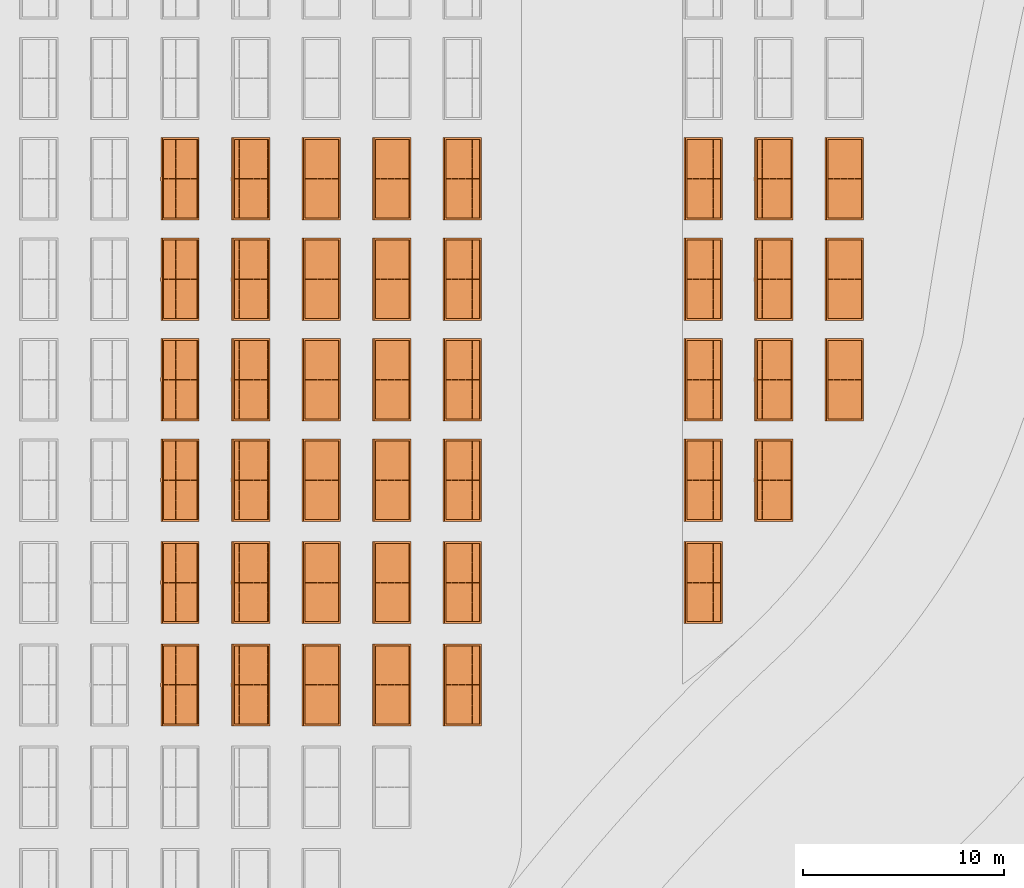
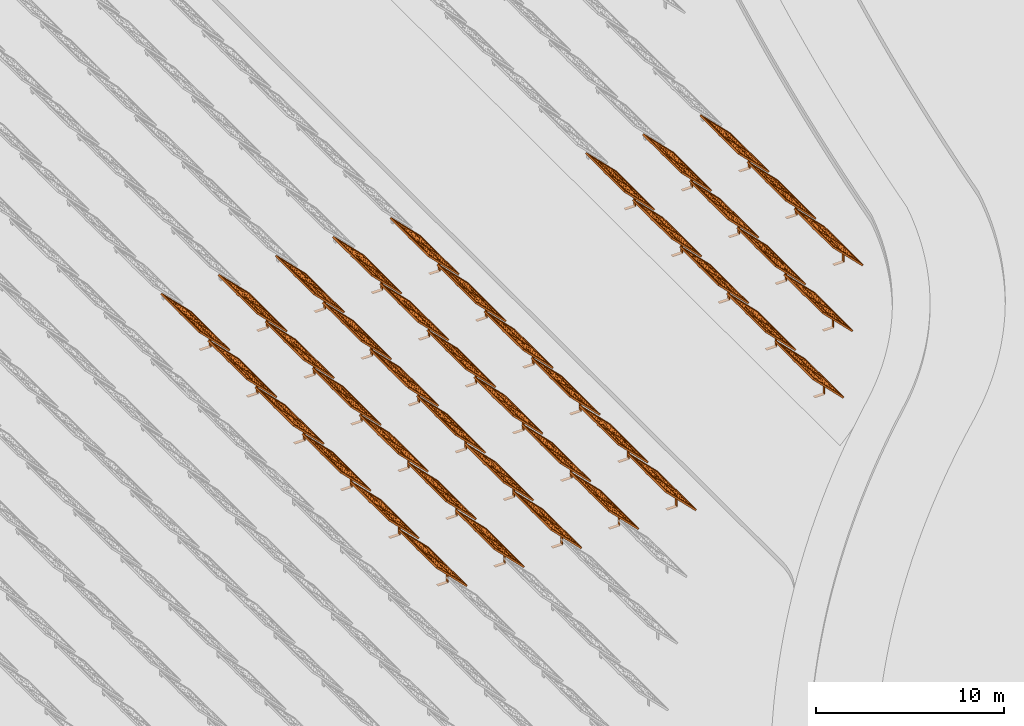
# One storey, part 18 of 39: 42 proxies.
"""IFC2X3 building model written with IfcOpenShell, lengths in millimetres."""

from ifc_helpers import new_model, entity, si_unit, converted_unit, derived_unit, direction, frame, frame_2d, origin, origin_2d_with_axis, place, context, subcontext, project, spatial, polyline, rectangle, outline, extrude, source, transform, mapped, material, material_list, element, save


model = new_model("IFC2X3")

# Units and contexts
model_context = context("Model", 3, precision=1e-06, world=origin(), true_north=direction((2.0, 6.12303176911189e-17, 1.0)))
context_of_model = context(None, 3, precision=1e-06, world=origin(), true_north=direction((2.0, 6.12303176911189e-17, 1.0)))
body_context = subcontext(model_context, "Body", "Model", "MODEL_VIEW")
ifc_project = project(units=[si_unit("LENGTHUNIT", "METRE", prefix="MILLI"), si_unit("AREAUNIT", "SQUARE_METRE", prefix="MILLI"), si_unit("VOLUMEUNIT", "CUBIC_METRE", prefix="MILLI"), converted_unit("PLANEANGLEUNIT", "DEGREE", entity("IfcRatioMeasure", 0.0174532925199433), si_unit("PLANEANGLEUNIT", "RADIAN"), dimensions=[0, 0, 0, 0, 0, 0, 0]), si_unit("MASSUNIT", "GRAM", prefix="KILO"), si_unit("TIMEUNIT", "SECOND"), si_unit("THERMODYNAMICTEMPERATUREUNIT", "KELVIN"), derived_unit("THERMALTRANSMITTANCEUNIT", [(si_unit("MASSUNIT", "GRAM", prefix="KILO"), 1), (si_unit("THERMODYNAMICTEMPERATUREUNIT", "KELVIN"), -1), (si_unit("TIMEUNIT", "SECOND"), -3)]), derived_unit("VOLUMETRICFLOWRATEUNIT", [(si_unit("LENGTHUNIT", "METRE"), 3), (si_unit("TIMEUNIT", "SECOND"), -1)])], contexts=[model_context, context_of_model])

# Site, building, storey
site_placement = place(None, origin())
site = spatial("IfcSite", under=ifc_project, at=site_placement, CompositionType="ELEMENT")
building_placement = place(site_placement, origin())
building = spatial("IfcBuilding", under=site, at=building_placement, CompositionType="ELEMENT")
storey_placement = place(building_placement, frame((0.0, 0.0, 4000.0)))
storey = spatial("IfcBuildingStorey", under=building, at=storey_placement, Name="Level 2", CompositionType="ELEMENT", Elevation=4000.0)

# Proxies
ifc_material_1 = material(Name="Stand-Steel")
ifc_material_2 = material(Name="Aluminium")
ifc_material_3 = material(Name="Glass")
ifc_material_list_1 = material_list([ifc_material_1, ifc_material_2, ifc_material_3])
shared_shape = source(origin(), body_context, "Body", "SweptSolid", [
    extrude(outline(polyline([(-629.526235435404, -220.0), (329.763117717702, -220.0), (329.763117717703, 410.0), (299.763117717703, 410.0), (299.763117717702, -190.0), (-629.526235435404, -190.0), (-629.526235435404, -220.0)])), frame((-190.00003127179, -100.0, 299.763117717707), z_axis=(0.0, 1.0, 0.0), x_axis=(0.0, 0.0, -1.0)), (0.0, 0.0, 1.0), 200.0),
    extrude(rectangle(XDim=20.0000000000001, YDim=200.0, at=frame_2d((0.0, -7.105427357601e-14), x_axis=(0.0, 1.0))), frame((-7.07109908365613, 0.0, 922.21828534124), z_axis=(-0.70710678118654, 0.0, 0.707106781186555), x_axis=(0.0, 1.0, 0.0)), (0.0, 0.0, 1.0), 2600.0),
    extrude(rectangle(XDim=24.9999999999997, YDim=24.9999999999999, at=frame_2d((2.87769807982841e-13, -9.50350909079134e-14), x_axis=(1.0, 0.0))), frame((-1449.56292018118, -1950.0, 2449.57494522722), z_axis=(0.0, 1.0, 0.0), x_axis=(-0.707106781186548, 0.0, -0.707106781186548)), (0.0, 0.0, 1.0), 3900.0),
    extrude(rectangle(XDim=24.9999999999999, YDim=25.0000000000001, at=origin_2d_with_axis()), frame((-1096.0095295879, -1950.0, 2096.02155463395), z_axis=(0.0, 1.0, 0.0), x_axis=(-0.707106781186542, 0.0, -0.707106781186553)), (0.0, 0.0, 1.0), 3900.0),
    extrude(rectangle(XDim=24.9999999999999, YDim=25.0000000000001, at=origin_2d_with_axis()), frame((-742.456138994631, -1950.0, 1742.46816404067), z_axis=(0.0, 1.0, 0.0), x_axis=(-0.707106781186542, 0.0, -0.707106781186553)), (0.0, 0.0, 1.0), 3900.0),
    extrude(rectangle(XDim=25.0, YDim=24.9999999999997, at=frame_2d((-7.19424519957101e-14, 1.19904086659517e-13), x_axis=(1.0, 0.0))), frame((-388.902748401358, -1950.0, 1388.9147734474), z_axis=(0.0, 1.0, 0.0), x_axis=(-0.707106781186545, 0.0, -0.70710678118655)), (0.0, 0.0, 1.0), 3900.0),
    extrude(rectangle(XDim=25.0000000000002, YDim=25.0, at=frame_2d((1.35891298214119e-13, 6.21724893790088e-15), x_axis=(0.0, 1.0))), frame((-35.3553703311048, 1500.0, 1035.35537033109), z_axis=(-0.707106781186544, 0.0, 0.707106781186551), x_axis=(0.0, 1.0, 0.0)), (0.0, 0.0, 1.0), 2440.0),
    extrude(rectangle(XDim=25.0000000000002, YDim=25.0, at=frame_2d((0.0, 1.77635683940025e-15), x_axis=(0.0, 1.0))), frame((-35.3553703311059, 1000.0, 1035.35537033109), z_axis=(-0.707106781186546, 0.0, 0.707106781186549), x_axis=(0.0, 1.0, 0.0)), (0.0, 0.0, 1.0), 2440.0),
    extrude(rectangle(XDim=25.0000000000002, YDim=25.0, at=frame_2d((0.0, 8.43769498715119e-14), x_axis=(0.0, 1.0))), frame((-26.5165355662756, 0.0, 1044.19420509593), z_axis=(-0.707106781186546, 0.0, 0.707106781186549), x_axis=(0.0, -1.0, 0.0)), (0.0, 0.0, 1.0), 2440.0),
    extrude(rectangle(XDim=25.0000000000002, YDim=25.0, at=frame_2d((0.0, 8.88178419700125e-16), x_axis=(0.0, 1.0))), frame((-35.3553703311065, 500.0, 1035.35537033109), z_axis=(-0.707106781186546, 0.0, 0.707106781186549), x_axis=(0.0, 1.0, 0.0)), (0.0, 0.0, 1.0), 2440.0),
    extrude(rectangle(XDim=25.0000000000002, YDim=25.0, at=frame_2d((0.0, 8.88178419700125e-16), x_axis=(0.0, 1.0))), frame((-35.3553703311086, -500.0, 1035.35537033109), z_axis=(-0.707106781186546, 0.0, 0.707106781186549), x_axis=(0.0, 1.0, 0.0)), (0.0, 0.0, 1.0), 2440.0),
    extrude(rectangle(XDim=25.0000000000002, YDim=25.0, at=frame_2d((0.0, 8.88178419700125e-16), x_axis=(0.0, 1.0))), frame((-35.3553703311095, -1000.0, 1035.35537033109), z_axis=(-0.707106781186546, 0.0, 0.707106781186549), x_axis=(0.0, 1.0, 0.0)), (0.0, 0.0, 1.0), 2440.0),
    extrude(rectangle(XDim=25.0000000000002, YDim=25.0, at=frame_2d((1.35891298214119e-13, 1.77635683940025e-15), x_axis=(0.0, 1.0))), frame((-35.3553703311107, -1500.0, 1035.35537033109), z_axis=(-0.707106781186546, 0.0, 0.707106781186549), x_axis=(0.0, 1.0, 0.0)), (0.0, 0.0, 1.0), 2440.0),
    extrude(rectangle(XDim=2400.0, YDim=11.9999999999994, at=frame_2d((-1.13686837721616e-13, 2.02948768901479e-13), x_axis=(1.0, 0.0))), frame((-883.883507754966, -1950.0, 1883.88350775495), z_axis=(0.0, 1.0, 0.0), x_axis=(0.707106781186546, 0.0, -0.707106781186549)), (0.0, 0.0, 1.0), 3900.0),
    extrude(outline(polyline([(-2050.0, -1300.0), (2050.0, -1300.0), (2050.0, 1300.0), (-2050.0, 1300.0), (-2050.0, -1300.0)]), holes=[polyline([(1950.0, -1200.0), (-1950.0, -1200.0), (-1950.0, 1200.0), (1950.0, 1200.0), (1950.0, -1200.0)])]), frame((-919.238846814293, 0.0, 1848.52816869563), z_axis=(0.707106781186554, 0.0, 0.707106781186541), x_axis=(0.0, 1.0, 0.0)), (0.0, 0.0, 1.0), 99.9999999999898),
])
proxy_1_placement = place(storey_placement, frame((-140870.317940101, 485144.680552409, 30.0)))
element("IfcBuildingElementProxy", 1, at=proxy_1_placement, inside=storey, material=ifc_material_list_1, Name="Solar Panel_4000X2500:Solar Panel_4000X2500", ObjectType="Solar Panel_4000X2500", CompositionType="ELEMENT", context=body_context, shape_type="MappedRepresentation", body=[
    mapped(shared_shape, transform((0.0, 0.0, 0.0), scale=1.0)),
])
ifc_material_list_2 = material_list([ifc_material_1, ifc_material_2, ifc_material_3])
proxy_2_placement = place(storey_placement, frame((-140870.317940101, 490144.680552409, 30.0)))
element("IfcBuildingElementProxy", 2, at=proxy_2_placement, inside=storey, material=ifc_material_list_2, Name="Solar Panel_4000X2500:Solar Panel_4000X2500", ObjectType="Solar Panel_4000X2500", CompositionType="ELEMENT", context=body_context, shape_type="MappedRepresentation", body=[
    mapped(shared_shape, transform((0.0, 0.0, 0.0), scale=1.0)),
])
ifc_material_list_3 = material_list([ifc_material_1, ifc_material_2, ifc_material_3])
proxy_3_placement = place(storey_placement, frame((-140870.317940101, 495144.680552409, 30.0)))
element("IfcBuildingElementProxy", 3, at=proxy_3_placement, inside=storey, material=ifc_material_list_3, Name="Solar Panel_4000X2500:Solar Panel_4000X2500", ObjectType="Solar Panel_4000X2500", CompositionType="ELEMENT", context=body_context, shape_type="MappedRepresentation", body=[
    mapped(shared_shape, transform((0.0, 0.0, 0.0), scale=1.0)),
])
ifc_material_list_4 = material_list([ifc_material_1, ifc_material_2, ifc_material_3])
proxy_4_placement = place(storey_placement, frame((-144385.32831183, 485144.680552409, 30.0)))
element("IfcBuildingElementProxy", 4, at=proxy_4_placement, inside=storey, material=ifc_material_list_4, Name="Solar Panel_4000X2500:Solar Panel_4000X2500", ObjectType="Solar Panel_4000X2500", CompositionType="ELEMENT", context=body_context, shape_type="MappedRepresentation", body=[
    mapped(shared_shape, transform((0.0, 0.0, 0.0), scale=1.0)),
])
ifc_material_list_5 = material_list([ifc_material_1, ifc_material_2, ifc_material_3])
proxy_5_placement = place(storey_placement, frame((-144385.32831183, 490144.680552409, 30.0)))
element("IfcBuildingElementProxy", 5, at=proxy_5_placement, inside=storey, material=ifc_material_list_5, Name="Solar Panel_4000X2500:Solar Panel_4000X2500", ObjectType="Solar Panel_4000X2500", CompositionType="ELEMENT", context=body_context, shape_type="MappedRepresentation", body=[
    mapped(shared_shape, transform((0.0, 0.0, 0.0), scale=1.0)),
])
ifc_material_list_6 = material_list([ifc_material_1, ifc_material_2, ifc_material_3])
proxy_6_placement = place(storey_placement, frame((-144385.32831183, 495144.680552409, 30.0)))
element("IfcBuildingElementProxy", 6, at=proxy_6_placement, inside=storey, material=ifc_material_list_6, Name="Solar Panel_4000X2500:Solar Panel_4000X2500", ObjectType="Solar Panel_4000X2500", CompositionType="ELEMENT", context=body_context, shape_type="MappedRepresentation", body=[
    mapped(shared_shape, transform((0.0, 0.0, 0.0), scale=1.0)),
])
ifc_material_list_7 = material_list([ifc_material_1, ifc_material_2, ifc_material_3])
proxy_7_placement = place(storey_placement, frame((-144385.32831183, 480144.680552409, 30.0)))
element("IfcBuildingElementProxy", 7, at=proxy_7_placement, inside=storey, material=ifc_material_list_7, Name="Solar Panel_4000X2500:Solar Panel_4000X2500", ObjectType="Solar Panel_4000X2500", CompositionType="ELEMENT", context=body_context, shape_type="MappedRepresentation", body=[
    mapped(shared_shape, transform((0.0, 0.0, 0.0), scale=1.0)),
])
ifc_material_list_8 = material_list([ifc_material_1, ifc_material_2, ifc_material_3])
proxy_8_placement = place(storey_placement, frame((-147885.32831183, 485144.680552409, 30.0)))
element("IfcBuildingElementProxy", 8, at=proxy_8_placement, inside=storey, material=ifc_material_list_8, Name="Solar Panel_4000X2500:Solar Panel_4000X2500", ObjectType="Solar Panel_4000X2500", CompositionType="ELEMENT", context=body_context, shape_type="MappedRepresentation", body=[
    mapped(shared_shape, transform((0.0, 0.0, 0.0), scale=1.0)),
])
ifc_material_list_9 = material_list([ifc_material_1, ifc_material_2, ifc_material_3])
proxy_9_placement = place(storey_placement, frame((-147885.32831183, 490144.680552409, 30.0)))
element("IfcBuildingElementProxy", 9, at=proxy_9_placement, inside=storey, material=ifc_material_list_9, Name="Solar Panel_4000X2500:Solar Panel_4000X2500", ObjectType="Solar Panel_4000X2500", CompositionType="ELEMENT", context=body_context, shape_type="MappedRepresentation", body=[
    mapped(shared_shape, transform((0.0, 0.0, 0.0), scale=1.0)),
])
ifc_material_list_10 = material_list([ifc_material_1, ifc_material_2, ifc_material_3])
proxy_10_placement = place(storey_placement, frame((-147885.32831183, 495144.680552409, 30.0)))
element("IfcBuildingElementProxy", 10, at=proxy_10_placement, inside=storey, material=ifc_material_list_10, Name="Solar Panel_4000X2500:Solar Panel_4000X2500", ObjectType="Solar Panel_4000X2500", CompositionType="ELEMENT", context=body_context, shape_type="MappedRepresentation", body=[
    mapped(shared_shape, transform((0.0, 0.0, 0.0), scale=1.0)),
])
ifc_material_list_11 = material_list([ifc_material_1, ifc_material_2, ifc_material_3])
proxy_11_placement = place(storey_placement, frame((-147885.32831183, 480144.680552409, 30.0)))
element("IfcBuildingElementProxy", 11, at=proxy_11_placement, inside=storey, material=ifc_material_list_11, Name="Solar Panel_4000X2500:Solar Panel_4000X2500", ObjectType="Solar Panel_4000X2500", CompositionType="ELEMENT", context=body_context, shape_type="MappedRepresentation", body=[
    mapped(shared_shape, transform((0.0, 0.0, 0.0), scale=1.0)),
])
ifc_material_list_12 = material_list([ifc_material_1, ifc_material_2, ifc_material_3])
proxy_12_placement = place(storey_placement, frame((-147885.32831183, 475044.680552409, 30.0)))
element("IfcBuildingElementProxy", 12, at=proxy_12_placement, inside=storey, material=ifc_material_list_12, Name="Solar Panel_4000X2500:Solar Panel_4000X2500", ObjectType="Solar Panel_4000X2500", CompositionType="ELEMENT", context=body_context, shape_type="MappedRepresentation", body=[
    mapped(shared_shape, transform((0.0, 0.0, 0.0), scale=1.0)),
])
ifc_material_list_13 = material_list([ifc_material_1, ifc_material_2, ifc_material_3])
proxy_13_placement = place(storey_placement, frame((-159885.32831183, 485144.680552409, 30.0)))
element("IfcBuildingElementProxy", 13, at=proxy_13_placement, inside=storey, material=ifc_material_list_13, Name="Solar Panel_4000X2500:Solar Panel_4000X2500", ObjectType="Solar Panel_4000X2500", CompositionType="ELEMENT", context=body_context, shape_type="MappedRepresentation", body=[
    mapped(shared_shape, transform((0.0, 0.0, 0.0), scale=1.0)),
])
ifc_material_list_14 = material_list([ifc_material_1, ifc_material_2, ifc_material_3])
proxy_14_placement = place(storey_placement, frame((-159885.32831183, 490144.680552409, 30.0)))
element("IfcBuildingElementProxy", 14, at=proxy_14_placement, inside=storey, material=ifc_material_list_14, Name="Solar Panel_4000X2500:Solar Panel_4000X2500", ObjectType="Solar Panel_4000X2500", CompositionType="ELEMENT", context=body_context, shape_type="MappedRepresentation", body=[
    mapped(shared_shape, transform((0.0, 0.0, 0.0), scale=1.0)),
])
ifc_material_list_15 = material_list([ifc_material_1, ifc_material_2, ifc_material_3])
proxy_15_placement = place(storey_placement, frame((-159885.32831183, 495144.680552409, 30.0)))
element("IfcBuildingElementProxy", 15, at=proxy_15_placement, inside=storey, material=ifc_material_list_15, Name="Solar Panel_4000X2500:Solar Panel_4000X2500", ObjectType="Solar Panel_4000X2500", CompositionType="ELEMENT", context=body_context, shape_type="MappedRepresentation", body=[
    mapped(shared_shape, transform((0.0, 0.0, 0.0), scale=1.0)),
])
ifc_material_list_16 = material_list([ifc_material_1, ifc_material_2, ifc_material_3])
proxy_16_placement = place(storey_placement, frame((-159885.32831183, 480144.680552409, 30.0)))
element("IfcBuildingElementProxy", 16, at=proxy_16_placement, inside=storey, material=ifc_material_list_16, Name="Solar Panel_4000X2500:Solar Panel_4000X2500", ObjectType="Solar Panel_4000X2500", CompositionType="ELEMENT", context=body_context, shape_type="MappedRepresentation", body=[
    mapped(shared_shape, transform((0.0, 0.0, 0.0), scale=1.0)),
])
ifc_material_list_17 = material_list([ifc_material_1, ifc_material_2, ifc_material_3])
proxy_17_placement = place(storey_placement, frame((-159885.32831183, 475044.680552409, 30.0)))
element("IfcBuildingElementProxy", 17, at=proxy_17_placement, inside=storey, material=ifc_material_list_17, Name="Solar Panel_4000X2500:Solar Panel_4000X2500", ObjectType="Solar Panel_4000X2500", CompositionType="ELEMENT", context=body_context, shape_type="MappedRepresentation", body=[
    mapped(shared_shape, transform((0.0, 0.0, 0.0), scale=1.0)),
])
ifc_material_list_18 = material_list([ifc_material_1, ifc_material_2, ifc_material_3])
proxy_18_placement = place(storey_placement, frame((-159885.32831183, 469944.680552409, 30.0)))
element("IfcBuildingElementProxy", 18, at=proxy_18_placement, inside=storey, material=ifc_material_list_18, Name="Solar Panel_4000X2500:Solar Panel_4000X2500", ObjectType="Solar Panel_4000X2500", CompositionType="ELEMENT", context=body_context, shape_type="MappedRepresentation", body=[
    mapped(shared_shape, transform((0.0, 0.0, 0.0), scale=1.0)),
])
ifc_material_list_19 = material_list([ifc_material_1, ifc_material_2, ifc_material_3])
proxy_19_placement = place(storey_placement, frame((-163400.32831183, 485144.680552409, 30.0)))
element("IfcBuildingElementProxy", 19, at=proxy_19_placement, inside=storey, material=ifc_material_list_19, Name="Solar Panel_4000X2500:Solar Panel_4000X2500", ObjectType="Solar Panel_4000X2500", CompositionType="ELEMENT", context=body_context, shape_type="MappedRepresentation", body=[
    mapped(shared_shape, transform((0.0, 0.0, 0.0), scale=1.0)),
])
ifc_material_list_20 = material_list([ifc_material_1, ifc_material_2, ifc_material_3])
proxy_20_placement = place(storey_placement, frame((-163400.32831183, 490144.680552409, 30.0)))
element("IfcBuildingElementProxy", 20, at=proxy_20_placement, inside=storey, material=ifc_material_list_20, Name="Solar Panel_4000X2500:Solar Panel_4000X2500", ObjectType="Solar Panel_4000X2500", CompositionType="ELEMENT", context=body_context, shape_type="MappedRepresentation", body=[
    mapped(shared_shape, transform((0.0, 0.0, 0.0), scale=1.0)),
])
ifc_material_list_21 = material_list([ifc_material_1, ifc_material_2, ifc_material_3])
proxy_21_placement = place(storey_placement, frame((-163400.32831183, 495144.680552409, 30.0)))
element("IfcBuildingElementProxy", 21, at=proxy_21_placement, inside=storey, material=ifc_material_list_21, Name="Solar Panel_4000X2500:Solar Panel_4000X2500", ObjectType="Solar Panel_4000X2500", CompositionType="ELEMENT", context=body_context, shape_type="MappedRepresentation", body=[
    mapped(shared_shape, transform((0.0, 0.0, 0.0), scale=1.0)),
])
ifc_material_list_22 = material_list([ifc_material_1, ifc_material_2, ifc_material_3])
proxy_22_placement = place(storey_placement, frame((-163400.32831183, 480144.680552409, 30.0)))
element("IfcBuildingElementProxy", 22, at=proxy_22_placement, inside=storey, material=ifc_material_list_22, Name="Solar Panel_4000X2500:Solar Panel_4000X2500", ObjectType="Solar Panel_4000X2500", CompositionType="ELEMENT", context=body_context, shape_type="MappedRepresentation", body=[
    mapped(shared_shape, transform((0.0, 0.0, 0.0), scale=1.0)),
])
ifc_material_list_23 = material_list([ifc_material_1, ifc_material_2, ifc_material_3])
proxy_23_placement = place(storey_placement, frame((-163400.32831183, 475044.680552409, 30.0)))
element("IfcBuildingElementProxy", 23, at=proxy_23_placement, inside=storey, material=ifc_material_list_23, Name="Solar Panel_4000X2500:Solar Panel_4000X2500", ObjectType="Solar Panel_4000X2500", CompositionType="ELEMENT", context=body_context, shape_type="MappedRepresentation", body=[
    mapped(shared_shape, transform((0.0, 0.0, 0.0), scale=1.0)),
])
ifc_material_list_24 = material_list([ifc_material_1, ifc_material_2, ifc_material_3])
proxy_24_placement = place(storey_placement, frame((-163400.32831183, 469944.680552409, 30.0)))
element("IfcBuildingElementProxy", 24, at=proxy_24_placement, inside=storey, material=ifc_material_list_24, Name="Solar Panel_4000X2500:Solar Panel_4000X2500", ObjectType="Solar Panel_4000X2500", CompositionType="ELEMENT", context=body_context, shape_type="MappedRepresentation", body=[
    mapped(shared_shape, transform((0.0, 0.0, 0.0), scale=1.0)),
])
ifc_material_list_25 = material_list([ifc_material_1, ifc_material_2, ifc_material_3])
proxy_25_placement = place(storey_placement, frame((-166915.32831183, 485144.680552409, 30.0)))
element("IfcBuildingElementProxy", 25, at=proxy_25_placement, inside=storey, material=ifc_material_list_25, Name="Solar Panel_4000X2500:Solar Panel_4000X2500", ObjectType="Solar Panel_4000X2500", CompositionType="ELEMENT", context=body_context, shape_type="MappedRepresentation", body=[
    mapped(shared_shape, transform((0.0, 0.0, 0.0), scale=1.0)),
])
ifc_material_list_26 = material_list([ifc_material_1, ifc_material_2, ifc_material_3])
proxy_26_placement = place(storey_placement, frame((-166915.32831183, 490144.680552409, 30.0)))
element("IfcBuildingElementProxy", 26, at=proxy_26_placement, inside=storey, material=ifc_material_list_26, Name="Solar Panel_4000X2500:Solar Panel_4000X2500", ObjectType="Solar Panel_4000X2500", CompositionType="ELEMENT", context=body_context, shape_type="MappedRepresentation", body=[
    mapped(shared_shape, transform((0.0, 0.0, 0.0), scale=1.0)),
])
ifc_material_list_27 = material_list([ifc_material_1, ifc_material_2, ifc_material_3])
proxy_27_placement = place(storey_placement, frame((-166915.32831183, 495144.680552409, 30.0)))
element("IfcBuildingElementProxy", 27, at=proxy_27_placement, inside=storey, material=ifc_material_list_27, Name="Solar Panel_4000X2500:Solar Panel_4000X2500", ObjectType="Solar Panel_4000X2500", CompositionType="ELEMENT", context=body_context, shape_type="MappedRepresentation", body=[
    mapped(shared_shape, transform((0.0, 0.0, 0.0), scale=1.0)),
])
ifc_material_list_28 = material_list([ifc_material_1, ifc_material_2, ifc_material_3])
proxy_28_placement = place(storey_placement, frame((-166915.32831183, 480144.680552409, 30.0)))
element("IfcBuildingElementProxy", 28, at=proxy_28_placement, inside=storey, material=ifc_material_list_28, Name="Solar Panel_4000X2500:Solar Panel_4000X2500", ObjectType="Solar Panel_4000X2500", CompositionType="ELEMENT", context=body_context, shape_type="MappedRepresentation", body=[
    mapped(shared_shape, transform((0.0, 0.0, 0.0), scale=1.0)),
])
ifc_material_list_29 = material_list([ifc_material_1, ifc_material_2, ifc_material_3])
proxy_29_placement = place(storey_placement, frame((-166915.32831183, 475044.680552409, 30.0)))
element("IfcBuildingElementProxy", 29, at=proxy_29_placement, inside=storey, material=ifc_material_list_29, Name="Solar Panel_4000X2500:Solar Panel_4000X2500", ObjectType="Solar Panel_4000X2500", CompositionType="ELEMENT", context=body_context, shape_type="MappedRepresentation", body=[
    mapped(shared_shape, transform((0.0, 0.0, 0.0), scale=1.0)),
])
ifc_material_list_30 = material_list([ifc_material_1, ifc_material_2, ifc_material_3])
proxy_30_placement = place(storey_placement, frame((-166915.32831183, 469944.680552409, 30.0)))
element("IfcBuildingElementProxy", 30, at=proxy_30_placement, inside=storey, material=ifc_material_list_30, Name="Solar Panel_4000X2500:Solar Panel_4000X2500", ObjectType="Solar Panel_4000X2500", CompositionType="ELEMENT", context=body_context, shape_type="MappedRepresentation", body=[
    mapped(shared_shape, transform((0.0, 0.0, 0.0), scale=1.0)),
])
ifc_material_list_31 = material_list([ifc_material_1, ifc_material_2, ifc_material_3])
proxy_31_placement = place(storey_placement, frame((-170430.32831183, 485144.680552409, 30.0)))
element("IfcBuildingElementProxy", 31, at=proxy_31_placement, inside=storey, material=ifc_material_list_31, Name="Solar Panel_4000X2500:Solar Panel_4000X2500", ObjectType="Solar Panel_4000X2500", CompositionType="ELEMENT", context=body_context, shape_type="MappedRepresentation", body=[
    mapped(shared_shape, transform((0.0, 0.0, 0.0), scale=1.0)),
])
ifc_material_list_32 = material_list([ifc_material_1, ifc_material_2, ifc_material_3])
proxy_32_placement = place(storey_placement, frame((-170430.32831183, 490144.680552409, 30.0)))
element("IfcBuildingElementProxy", 32, at=proxy_32_placement, inside=storey, material=ifc_material_list_32, Name="Solar Panel_4000X2500:Solar Panel_4000X2500", ObjectType="Solar Panel_4000X2500", CompositionType="ELEMENT", context=body_context, shape_type="MappedRepresentation", body=[
    mapped(shared_shape, transform((0.0, 0.0, 0.0), scale=1.0)),
])
ifc_material_list_33 = material_list([ifc_material_1, ifc_material_2, ifc_material_3])
proxy_33_placement = place(storey_placement, frame((-170430.32831183, 495144.680552409, 30.0)))
element("IfcBuildingElementProxy", 33, at=proxy_33_placement, inside=storey, material=ifc_material_list_33, Name="Solar Panel_4000X2500:Solar Panel_4000X2500", ObjectType="Solar Panel_4000X2500", CompositionType="ELEMENT", context=body_context, shape_type="MappedRepresentation", body=[
    mapped(shared_shape, transform((0.0, 0.0, 0.0), scale=1.0)),
])
ifc_material_list_34 = material_list([ifc_material_1, ifc_material_2, ifc_material_3])
proxy_34_placement = place(storey_placement, frame((-170430.32831183, 480144.680552409, 30.0)))
element("IfcBuildingElementProxy", 34, at=proxy_34_placement, inside=storey, material=ifc_material_list_34, Name="Solar Panel_4000X2500:Solar Panel_4000X2500", ObjectType="Solar Panel_4000X2500", CompositionType="ELEMENT", context=body_context, shape_type="MappedRepresentation", body=[
    mapped(shared_shape, transform((0.0, 0.0, 0.0), scale=1.0)),
])
ifc_material_list_35 = material_list([ifc_material_1, ifc_material_2, ifc_material_3])
proxy_35_placement = place(storey_placement, frame((-170430.32831183, 475044.680552409, 30.0)))
element("IfcBuildingElementProxy", 35, at=proxy_35_placement, inside=storey, material=ifc_material_list_35, Name="Solar Panel_4000X2500:Solar Panel_4000X2500", ObjectType="Solar Panel_4000X2500", CompositionType="ELEMENT", context=body_context, shape_type="MappedRepresentation", body=[
    mapped(shared_shape, transform((0.0, 0.0, 0.0), scale=1.0)),
])
ifc_material_list_36 = material_list([ifc_material_1, ifc_material_2, ifc_material_3])
proxy_36_placement = place(storey_placement, frame((-170430.32831183, 469944.680552409, 30.0)))
element("IfcBuildingElementProxy", 36, at=proxy_36_placement, inside=storey, material=ifc_material_list_36, Name="Solar Panel_4000X2500:Solar Panel_4000X2500", ObjectType="Solar Panel_4000X2500", CompositionType="ELEMENT", context=body_context, shape_type="MappedRepresentation", body=[
    mapped(shared_shape, transform((0.0, 0.0, 0.0), scale=1.0)),
])
ifc_material_list_37 = material_list([ifc_material_1, ifc_material_2, ifc_material_3])
proxy_37_placement = place(storey_placement, frame((-173945.32831183, 485144.680552409, 30.0)))
element("IfcBuildingElementProxy", 37, at=proxy_37_placement, inside=storey, material=ifc_material_list_37, Name="Solar Panel_4000X2500:Solar Panel_4000X2500", ObjectType="Solar Panel_4000X2500", CompositionType="ELEMENT", context=body_context, shape_type="MappedRepresentation", body=[
    mapped(shared_shape, transform((0.0, 0.0, 0.0), scale=1.0)),
])
ifc_material_list_38 = material_list([ifc_material_1, ifc_material_2, ifc_material_3])
proxy_38_placement = place(storey_placement, frame((-173945.32831183, 490144.680552409, 30.0)))
element("IfcBuildingElementProxy", 38, at=proxy_38_placement, inside=storey, material=ifc_material_list_38, Name="Solar Panel_4000X2500:Solar Panel_4000X2500", ObjectType="Solar Panel_4000X2500", CompositionType="ELEMENT", context=body_context, shape_type="MappedRepresentation", body=[
    mapped(shared_shape, transform((0.0, 0.0, 0.0), scale=1.0)),
])
ifc_material_list_39 = material_list([ifc_material_1, ifc_material_2, ifc_material_3])
proxy_39_placement = place(storey_placement, frame((-173945.32831183, 495144.680552409, 30.0)))
element("IfcBuildingElementProxy", 39, at=proxy_39_placement, inside=storey, material=ifc_material_list_39, Name="Solar Panel_4000X2500:Solar Panel_4000X2500", ObjectType="Solar Panel_4000X2500", CompositionType="ELEMENT", context=body_context, shape_type="MappedRepresentation", body=[
    mapped(shared_shape, transform((0.0, 0.0, 0.0), scale=1.0)),
])
ifc_material_list_40 = material_list([ifc_material_1, ifc_material_2, ifc_material_3])
proxy_40_placement = place(storey_placement, frame((-173945.32831183, 480144.680552409, 30.0)))
element("IfcBuildingElementProxy", 40, at=proxy_40_placement, inside=storey, material=ifc_material_list_40, Name="Solar Panel_4000X2500:Solar Panel_4000X2500", ObjectType="Solar Panel_4000X2500", CompositionType="ELEMENT", context=body_context, shape_type="MappedRepresentation", body=[
    mapped(shared_shape, transform((0.0, 0.0, 0.0), scale=1.0)),
])
ifc_material_list_41 = material_list([ifc_material_1, ifc_material_2, ifc_material_3])
proxy_41_placement = place(storey_placement, frame((-173945.32831183, 475044.680552409, 30.0)))
element("IfcBuildingElementProxy", 41, at=proxy_41_placement, inside=storey, material=ifc_material_list_41, Name="Solar Panel_4000X2500:Solar Panel_4000X2500", ObjectType="Solar Panel_4000X2500", CompositionType="ELEMENT", context=body_context, shape_type="MappedRepresentation", body=[
    mapped(shared_shape, transform((0.0, 0.0, 0.0), scale=1.0)),
])
ifc_material_list_42 = material_list([ifc_material_1, ifc_material_2, ifc_material_3])
proxy_42_placement = place(storey_placement, frame((-173945.32831183, 469944.680552409, 30.0)))
element("IfcBuildingElementProxy", 42, at=proxy_42_placement, inside=storey, material=ifc_material_list_42, Name="Solar Panel_4000X2500:Solar Panel_4000X2500", ObjectType="Solar Panel_4000X2500", CompositionType="ELEMENT", context=body_context, shape_type="MappedRepresentation", body=[
    mapped(shared_shape, transform((0.0, 0.0, 0.0), scale=1.0)),
])

save(model, "model.ifc")
